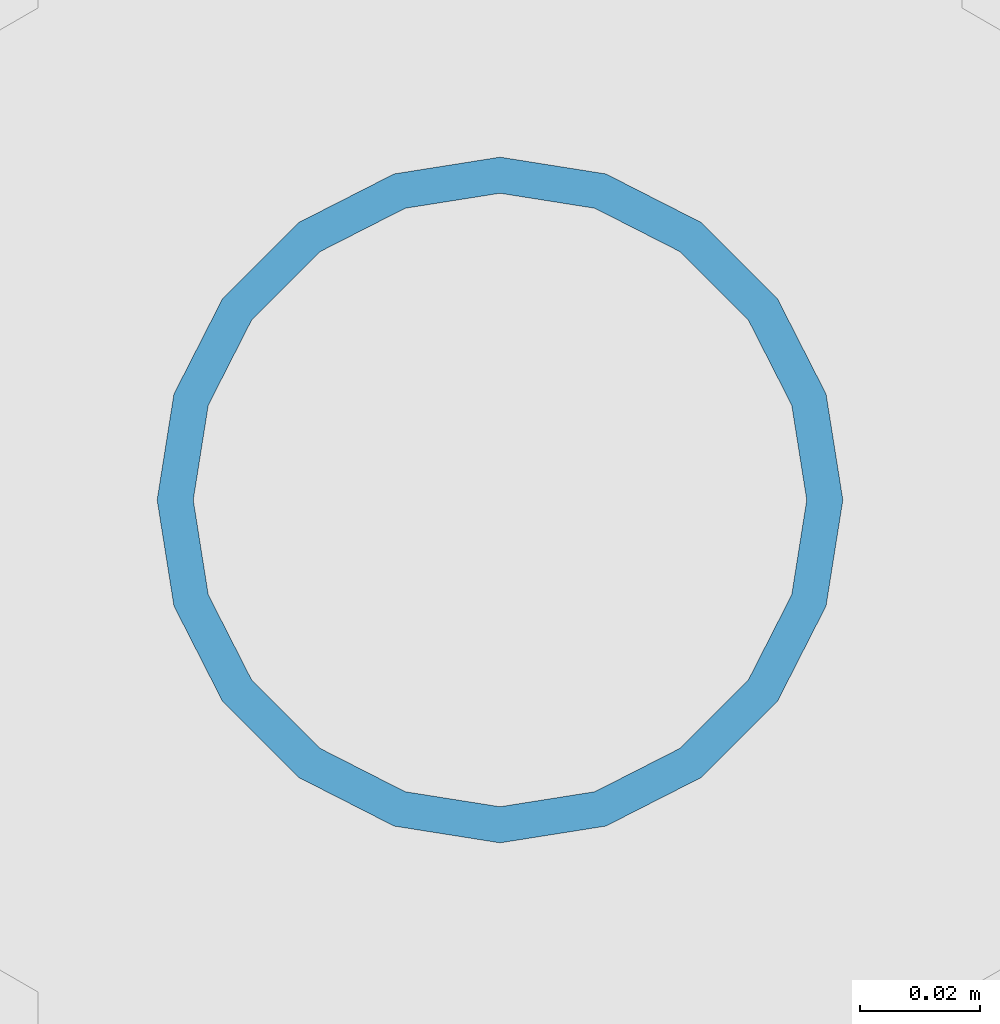
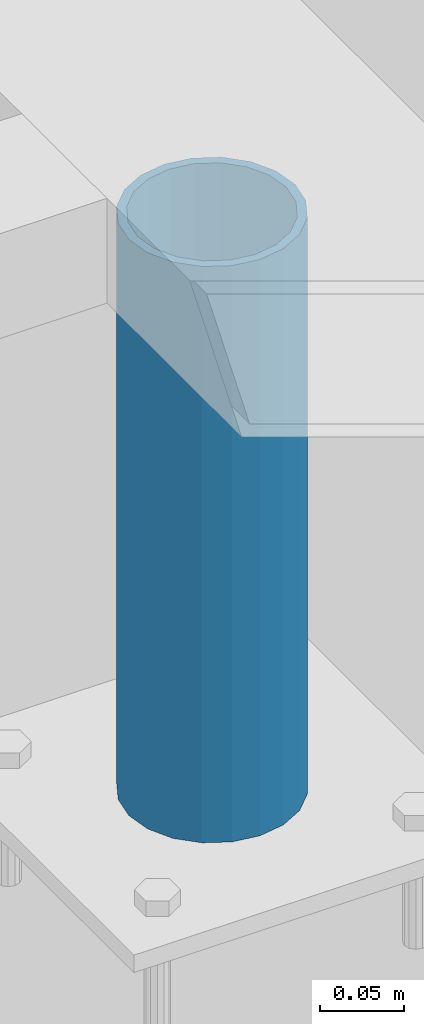
# One storey, part 565 of 1179: 1 column, 1 element without a shape of its own.
"""IFC2X3 building model written with IfcOpenShell, lengths in millimetres."""

from ifc_helpers import new_model, si_unit, frame, origin_with_axes, place, context, subcontext, project, spatial, faceted_brep, material, type_object, element, aggregate, save


model = new_model("IFC2X3")

# Units and contexts
model_context = context("Model", 3, precision=1e-05, world=origin_with_axes())
body_context = subcontext(model_context, "Body", "Model", "MODEL_VIEW")
ifc_project = project(units=[si_unit("LENGTHUNIT", "METRE", prefix="MILLI"), si_unit("AREAUNIT", "SQUARE_METRE"), si_unit("VOLUMEUNIT", "CUBIC_METRE"), si_unit("MASSUNIT", "GRAM", prefix="KILO"), si_unit("TIMEUNIT", "SECOND"), si_unit("PLANEANGLEUNIT", "RADIAN"), si_unit("SOLIDANGLEUNIT", "STERADIAN"), si_unit("THERMODYNAMICTEMPERATUREUNIT", "DEGREE_CELSIUS"), si_unit("LUMINOUSINTENSITYUNIT", "LUMEN")], contexts=[model_context])

# Site, building, storey
site_placement = place(None, origin_with_axes())
site = spatial("IfcSite", under=ifc_project, at=site_placement, CompositionType="ELEMENT")
building_placement = place(site_placement, origin_with_axes())
building = spatial("IfcBuilding", under=site, at=building_placement, Name="Undefined", CompositionType="ELEMENT")
storey_placement = place(building_placement, origin_with_axes())
storey = spatial("IfcBuildingStorey", under=building, at=storey_placement, Name="Undefined", CompositionType="ELEMENT", Elevation=0.0)

# Assembly, column
assembly_placement = place(storey_placement, origin_with_axes())
assembly = element("IfcElementAssembly", 1, at=assembly_placement, inside=storey, Name="FRAME", AssemblyPlace="NOTDEFINED", PredefinedType="RIGID_FRAME")
ifc_material = material()
column_type = type_object("IfcColumnType", Name="PIPE4SCH40", PredefinedType="NOTDEFINED")
column_placement = place(assembly_placement, frame((20575.5875, 38018.3225542222, 13265.15), z_axis=(0.0, 1.0, 0.0), x_axis=(0.0, 0.0, 1.0)))
column = element("IfcColumn", 2, at=column_placement, type_object=column_type, material=ifc_material, Name="COLUMN", ObjectType="PIPE4SCH40", context=body_context, shape_type="Brep", body=[
    faceted_brep([(0.0, -51.1301999999996, 0.0), (0.0, -48.6277098894752, 15.8001007257917), (419.099999999999, -48.6277098894752, 15.8001007257917), (419.099999999999, -51.1301999999996, 0.0), (0.0, -41.3652007257915, 30.0535775067619), (419.099999999999, -41.3652007257915, 30.0535775067619), (0.0, -30.0535775067656, 41.3652007257915), (419.099999999999, -30.0535775067656, 41.3652007257915), (0.0, -15.8001007257917, 48.6277098894716), (419.099999999999, -15.8001007257917, 48.6277098894716), (0.0, 0.0, 51.1301999999996), (419.099999999999, 0.0, 51.1301999999996), (0.0, 15.8001007257917, 48.6277098894716), (419.099999999999, 15.8001007257917, 48.6277098894716), (0.0, 30.0535775067656, 41.3652007257915), (419.099999999999, 30.0535775067656, 41.3652007257915), (0.0, 41.3652007257915, 30.0535775067619), (419.099999999999, 41.3652007257915, 30.0535775067619), (0.0, 48.6277098894752, 15.8001007257917), (419.099999999999, 48.6277098894752, 15.8001007257917), (0.0, 51.1301999999996, 0.0), (419.099999999999, 51.1301999999996, 0.0), (0.0, 48.6277098894752, -15.8001007257917), (419.099999999999, 48.6277098894752, -15.8001007257917), (0.0, 41.3652007257915, -30.0535775067619), (419.099999999999, 41.3652007257915, -30.0535775067619), (0.0, 30.0535775067656, -41.3652007257915), (419.099999999999, 30.0535775067656, -41.3652007257915), (0.0, 15.8001007257917, -48.6277098894716), (419.099999999999, 15.8001007257917, -48.6277098894716), (0.0, 0.0, -51.1301999999996), (419.099999999999, 0.0, -51.1301999999996), (0.0, -15.8001007257917, -48.6277098894716), (419.099999999999, -15.8001007257917, -48.6277098894716), (0.0, -30.0535775067656, -41.3652007257915), (419.099999999999, -30.0535775067656, -41.3652007257915), (0.0, -41.3652007257915, -30.0535775067619), (419.099999999999, -41.3652007257915, -30.0535775067619), (0.0, -48.6277098894752, -15.8001007257917), (419.099999999999, -48.6277098894752, -15.8001007257917), (0.0, -57.1500000000015, 0.0), (0.0, -54.3528799062697, -17.6603212285263), (419.099999999999, -54.3528799062697, -17.6603212285263), (419.099999999999, -57.1500000000015, 0.0), (0.0, -46.235321228527, -33.5919271685125), (419.099999999999, -46.235321228527, -33.5919271685125), (0.0, -33.5919271685161, -46.2353212285307), (419.099999999999, -33.5919271685161, -46.2353212285307), (0.0, -17.6603212285299, -54.3528799062697), (419.099999999999, -17.6603212285299, -54.3528799062697), (0.0, 0.0, -57.1500000000015), (419.099999999999, 0.0, -57.1500000000015), (0.0, 17.6603212285299, -54.3528799062697), (419.099999999999, 17.6603212285299, -54.3528799062697), (0.0, 33.5919271685161, -46.2353212285307), (419.099999999999, 33.5919271685161, -46.2353212285307), (0.0, 46.235321228527, -33.5919271685125), (419.099999999999, 46.235321228527, -33.5919271685125), (0.0, 54.3528799062697, -17.6603212285263), (419.099999999999, 54.3528799062697, -17.6603212285263), (0.0, 57.1500000000015, 0.0), (419.099999999999, 57.1500000000015, 0.0), (0.0, 54.3528799062697, 17.6603212285263), (419.099999999999, 54.3528799062697, 17.6603212285263), (0.0, 46.235321228527, 33.5919271685125), (419.099999999999, 46.235321228527, 33.5919271685125), (0.0, 33.5919271685161, 46.2353212285307), (419.099999999999, 33.5919271685161, 46.2353212285307), (0.0, 17.6603212285299, 54.3528799062697), (419.099999999999, 17.6603212285299, 54.3528799062697), (0.0, 0.0, 57.1500000000015), (419.099999999999, 0.0, 57.1500000000015), (0.0, -17.6603212285299, 54.3528799062697), (419.099999999999, -17.6603212285299, 54.3528799062697), (0.0, -33.5919271685161, 46.2353212285307), (419.099999999999, -33.5919271685161, 46.2353212285307), (0.0, -46.235321228527, 33.5919271685125), (419.099999999999, -46.235321228527, 33.5919271685125), (0.0, -54.3528799062697, 17.6603212285263), (419.099999999999, -54.3528799062697, 17.6603212285263)], [[[0, 1, 2, 3]], [[1, 4, 5, 2]], [[4, 6, 7, 5]], [[6, 8, 9, 7]], [[8, 10, 11, 9]], [[10, 12, 13, 11]], [[12, 14, 15, 13]], [[14, 16, 17, 15]], [[16, 18, 19, 17]], [[18, 20, 21, 19]], [[20, 22, 23, 21]], [[22, 24, 25, 23]], [[24, 26, 27, 25]], [[26, 28, 29, 27]], [[28, 30, 31, 29]], [[30, 32, 33, 31]], [[32, 34, 35, 33]], [[34, 36, 37, 35]], [[36, 38, 39, 37]], [[38, 0, 3, 39]], [[40, 41, 42, 43]], [[41, 44, 45, 42]], [[44, 46, 47, 45]], [[46, 48, 49, 47]], [[48, 50, 51, 49]], [[50, 52, 53, 51]], [[52, 54, 55, 53]], [[54, 56, 57, 55]], [[56, 58, 59, 57]], [[58, 60, 61, 59]], [[60, 62, 63, 61]], [[62, 64, 65, 63]], [[64, 66, 67, 65]], [[66, 68, 69, 67]], [[68, 70, 71, 69]], [[70, 72, 73, 71]], [[72, 74, 75, 73]], [[74, 76, 77, 75]], [[76, 78, 79, 77]], [[78, 40, 43, 79]], [[45, 47, 49, 51, 53, 55, 57, 59, 61, 63, 65, 67, 69, 71, 73, 75, 77, 79, 43, 42], [5, 7, 9, 11, 13, 15, 17, 19, 21, 23, 25, 27, 29, 31, 33, 35, 37, 39, 3, 2]], [[78, 76, 74, 72, 70, 68, 66, 64, 62, 60, 58, 56, 54, 52, 50, 48, 46, 44, 41, 40], [38, 36, 34, 32, 30, 28, 26, 24, 22, 20, 18, 16, 14, 12, 10, 8, 6, 4, 1, 0]]]),
])
aggregate(assembly, [column])

save(model, "model.ifc")
